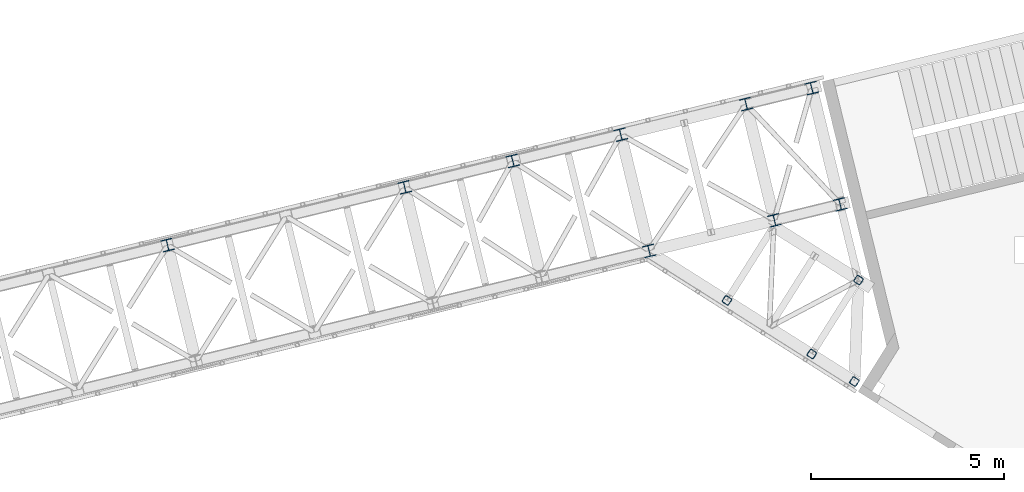
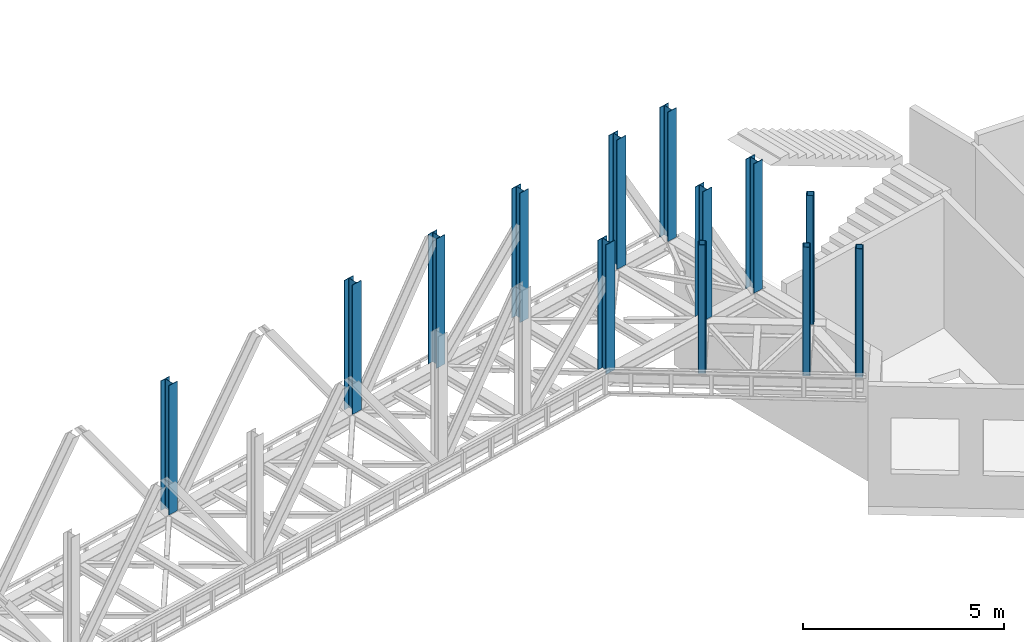
# One storey, part 3 of 93: 13 columns.
"""IFC4 building model written with IfcOpenShell, lengths in millimetres."""

from ifc_helpers import new_model, entity, si_unit, converted_unit, derived_unit, direction, frame, origin, place, context, subcontext, project, spatial, indexed_curve, outline, extrude, type_object, element, save


model = new_model("IFC4")

# Units and contexts
model_context = context("Model", 3, precision=0.01, world=origin(), true_north=direction((6.12303176911189e-17, 1.0)))
plan_context = context("Plan", 3, precision=0.01, world=origin(), true_north=direction((6.12303176911189e-17, 1.0)))
body_context = subcontext(model_context, "Body", "Model", "MODEL_VIEW")
ifc_project = project(units=[si_unit("LENGTHUNIT", "METRE", prefix="MILLI"), si_unit("AREAUNIT", "SQUARE_METRE"), si_unit("VOLUMEUNIT", "CUBIC_METRE"), converted_unit("PLANEANGLEUNIT", "DEGREE", entity("IfcRatioMeasure", 0.0174532925199433), si_unit("PLANEANGLEUNIT", "RADIAN"), dimensions=[0, 0, 0, 0, 0, 0, 0]), si_unit("MASSUNIT", "GRAM", prefix="KILO"), derived_unit("MASSDENSITYUNIT", [(si_unit("MASSUNIT", "GRAM", prefix="KILO"), 1), (si_unit("LENGTHUNIT", "METRE"), -3)]), derived_unit("MOMENTOFINERTIAUNIT", [(si_unit("LENGTHUNIT", "METRE"), 4)]), si_unit("TIMEUNIT", "SECOND"), si_unit("FREQUENCYUNIT", "HERTZ"), si_unit("THERMODYNAMICTEMPERATUREUNIT", "DEGREE_CELSIUS"), derived_unit("THERMALTRANSMITTANCEUNIT", [(si_unit("MASSUNIT", "GRAM", prefix="KILO"), 1), (si_unit("THERMODYNAMICTEMPERATUREUNIT", "KELVIN"), -1), (si_unit("TIMEUNIT", "SECOND"), -3)]), derived_unit("VOLUMETRICFLOWRATEUNIT", [(si_unit("LENGTHUNIT", "METRE"), 3), (si_unit("TIMEUNIT", "SECOND"), -1)]), derived_unit("MASSFLOWRATEUNIT", [(si_unit("MASSUNIT", "GRAM", prefix="KILO"), 1), (si_unit("TIMEUNIT", "SECOND"), -1)]), derived_unit("ROTATIONALFREQUENCYUNIT", [(si_unit("TIMEUNIT", "SECOND"), -1)]), si_unit("ELECTRICCURRENTUNIT", "AMPERE"), si_unit("ELECTRICVOLTAGEUNIT", "VOLT"), si_unit("POWERUNIT", "WATT"), si_unit("FORCEUNIT", "NEWTON", prefix="KILO"), si_unit("ILLUMINANCEUNIT", "LUX"), si_unit("LUMINOUSFLUXUNIT", "LUMEN"), si_unit("LUMINOUSINTENSITYUNIT", "CANDELA"), derived_unit("USERDEFINED", [(si_unit("MASSUNIT", "GRAM", prefix="KILO"), -1), (si_unit("LENGTHUNIT", "METRE"), -2), (si_unit("TIMEUNIT", "SECOND"), 3), (si_unit("LUMINOUSFLUXUNIT", "LUMEN"), 1)]), derived_unit("LINEARVELOCITYUNIT", [(si_unit("LENGTHUNIT", "METRE"), 1), (si_unit("TIMEUNIT", "SECOND"), -1)]), si_unit("PRESSUREUNIT", "PASCAL"), derived_unit("USERDEFINED", [(si_unit("LENGTHUNIT", "METRE"), -2), (si_unit("MASSUNIT", "GRAM", prefix="KILO"), 1), (si_unit("TIMEUNIT", "SECOND"), -2)]), derived_unit("LINEARFORCEUNIT", [(si_unit("MASSUNIT", "GRAM", prefix="KILO"), 1), (si_unit("LENGTHUNIT", "METRE"), 1), (si_unit("TIMEUNIT", "SECOND"), -2), (si_unit("LENGTHUNIT", "METRE"), -1)]), derived_unit("PLANARFORCEUNIT", [(si_unit("MASSUNIT", "GRAM", prefix="KILO"), 1), (si_unit("LENGTHUNIT", "METRE"), 1), (si_unit("TIMEUNIT", "SECOND"), -2), (si_unit("LENGTHUNIT", "METRE"), -2)])], contexts=[model_context, plan_context])

# Site, building, storey
site_placement = place(None, origin())
site = spatial("IfcSite", under=ifc_project, at=site_placement, CompositionType="ELEMENT")
building_placement = place(site_placement, origin())
building = spatial("IfcBuilding", under=site, at=building_placement, CompositionType="ELEMENT")
storey_placement = place(building_placement, frame((0.0, 0.0, 15900.0)))
storey = spatial("IfcBuildingStorey", under=building, at=storey_placement, CompositionType="ELEMENT", Elevation=15900.0)

# Columns
column_type_1 = type_object("IfcColumnType", PredefinedType="COLUMN")
column_1_placement = place(storey_placement, origin())
element("IfcColumn", 1, at=column_1_placement, inside=storey, type_object=column_type_1, ObjectType="Steel Column", PredefinedType="COLUMN", context=body_context, shape_type="SweptSolid", body=[
    extrude(outline(indexed_curve([(-149.999999999996, -149.999999999997), (-134.499999999996, -149.999999999997), (-134.499999999997, -22.9999999999994), (-133.1298315852, -16.1116982174372), (-129.227922061356, -10.2720779386417), (-123.388301782569, -6.37016841480137), (-116.499999999997, -5.0000000000034), (116.500000000004, -5.00000000000357), (123.388301782575, -6.37016841480053), (129.22792206136, -10.272077938641), (133.129831585207, -16.1116982174367), (134.500000000004, -22.9999999999993), (134.500000000004, -149.999999999996), (150.000000000004, -149.999999999997), (150.000000000002, 150.000000000005), (134.500000000004, 150.000000000004), (134.500000000003, 22.9999999999989), (133.129831585206, 16.1116982174278), (129.22792206136, 10.2720779386507), (123.388301782574, 6.37016841479246), (116.500000000003, 4.99999999999504), (-116.499999999999, 4.99999999999782), (-123.388301782571, 6.37016841478953), (-129.22792206136, 10.2720779386521), (-133.129831585201, 16.1116982174273), (-134.500000000001, 22.9999999999972), (-134.5, 149.999999999992), (-149.999999999998, 150.000000000004), (-149.999999999996, -149.999999999997)], self_intersect=False)), frame((-5412.09908652914, 16282.3206023644, 3685.0), z_axis=(0.0, 0.0, 1.0), x_axis=(-0.236826092990335, 0.971552058141474, 0.0)), (0.0, 0.0, 1.0), 3931.00000000001),
])
column_type_2 = type_object("IfcColumnType", PredefinedType="COLUMN")
column_2_placement = place(storey_placement, origin())
element("IfcColumn", 2, at=column_2_placement, inside=storey, type_object=column_type_2, ObjectType="Steel Column", PredefinedType="COLUMN", context=body_context, shape_type="SweptSolid", body=[
    extrude(outline(indexed_curve([(-149.999999999992, -150.000000000004), (-134.499999999992, -150.000000000004), (-134.499999999995, -23.0000000000064), (-133.129831585198, -16.1116982174347), (-129.227922061354, -10.2720779386484), (-123.388301782568, -6.37016841479899), (-116.499999999995, -5.00000000000143), (116.500000000005, -4.99999999999686), (123.388301782576, -6.3701684147945), (129.227922061362, -10.2720779386436), (133.129831585209, -16.1116982174297), (134.500000000006, -23.0000000000012), (134.500000000007, -149.999999999998), (150.000000000008, -149.999999999998), (150.000000000001, 150.000000000004), (134.500000000003, 150.000000000003), (134.500000000004, 23.0000000000146), (133.129831585207, 16.1116982174256), (129.227922061361, 10.2720779386482), (123.388301782575, 6.37016841479877), (116.500000000004, 5.00000000000095), (-116.499999999998, 5.00000000000006), (-123.388301782567, 6.37016841479402), (-129.227922061359, 10.2720779386449), (-133.129831585202, 16.1116982174205), (-134.5, 23.0000000000078), (-134.500000000001, 149.999999999996), (-149.999999999999, 149.999999999998), (-149.999999999992, -150.000000000004)], self_intersect=False)), frame((-2167.11521233662, 17073.3197529521, 3685.0), z_axis=(0.0, 0.0, 1.0), x_axis=(-0.236826092990319, 0.971552058141478, 0.0)), (0.0, 0.0, 1.0), 3931.00000000001),
])
column_type_3 = type_object("IfcColumnType", PredefinedType="COLUMN")
column_3_placement = place(storey_placement, origin())
element("IfcColumn", 3, at=column_3_placement, inside=storey, type_object=column_type_3, ObjectType="Steel Column", PredefinedType="COLUMN", context=body_context, shape_type="SweptSolid", body=[
    extrude(outline(indexed_curve([(-150.000000000001, -150.000000000001), (-134.5, -150.000000000001), (-134.500000000002, -22.9999999999947), (-133.129831585205, -16.1116982174319), (-129.227922061361, -10.2720779386456), (-123.388301782575, -6.37016841479614), (-116.500000000002, -4.9999999999988), (116.499999999999, -4.99999999999733), (123.38830178257, -6.37016841479492), (129.227922061355, -10.272077938644), (133.129831585202, -16.1116982174302), (134.499999999999, -22.9999999999931), (134.499999999999, -149.999999999999), (149.999999999999, -149.999999999999), (149.999999999997, 150.000000000003), (134.499999999998, 150.000000000002), (134.499999999998, 23.0000000000053), (133.129831585201, 16.1116982174337), (129.227922061355, 10.272077938639), (123.388301782568, 6.37016841480707), (116.499999999998, 5.00000000000929), (-116.500000000006, 4.99999999999419), (-123.388301782583, 6.37016841479406), (-129.227922061363, 10.2720779386316), (-133.129831585209, 16.1116982174316), (-134.500000000006, 23.0000000000023), (-134.500000000006, 149.999999999999), (-150.000000000003, 150.0), (-150.000000000001, -150.000000000001)], self_intersect=False)), frame((-466.899110589044, 17487.7654156852, 3685.0), z_axis=(0.0, 0.0, 1.0), x_axis=(-0.236826092990331, 0.971552058141475, 0.0)), (0.0, 0.0, 1.0), 3931.00000000001),
])
column_type_4 = type_object("IfcColumnType", PredefinedType="COLUMN")
column_4_placement = place(storey_placement, origin())
element("IfcColumn", 4, at=column_4_placement, inside=storey, type_object=column_type_4, ObjectType="Steel Column", PredefinedType="COLUMN", context=body_context, shape_type="SweptSolid", body=[
    extrude(outline(indexed_curve([(-150.000000000009, -149.999999999989), (-134.500000000008, -149.999999999989), (-134.499999999999, -22.9999999999834), (-133.129831585204, -16.1116982174208), (-129.227922061357, -10.2720779386351), (-123.38830178257, -6.37016841478617), (-116.499999999998, -4.99999999998972), (116.500000000001, -5.00000000000413), (123.388301782572, -6.37016841480157), (129.227922061359, -10.272077938653), (133.129831585204, -16.1116982174384), (134.5, -23.0000000000022), (134.499999999993, -150.000000000008), (149.999999999993, -150.000000000008), (150.000000000012, 149.999999999992), (134.500000000012, 149.999999999994), (134.500000000005, 22.9999999999887), (133.129831585207, 16.1116982174245), (129.22792206136, 10.2720779386298), (123.388301782574, 6.37016841478987), (116.500000000003, 4.9999999999929), (-116.499999999999, 5.00000000001255), (-123.388301782573, 6.3701684148084), (-129.227922061357, 10.2720779386504), (-133.129831585205, 16.111698217441), (-134.499999999997, 23.0000000000127), (-134.499999999989, 150.000000000016), (-149.999999999988, 150.000000000013), (-150.000000000009, -149.999999999989)], self_intersect=False)), frame((-17882.6088371482, 16433.2727792797, 3685.0), z_axis=(0.0, 0.0, 1.0), x_axis=(-0.236826092990401, 0.971552058141458, 0.0)), (0.0, 0.0, 1.0), 3931.00000000001),
])
column_type_5 = type_object("IfcColumnType", PredefinedType="COLUMN")
column_5_placement = place(storey_placement, origin())
element("IfcColumn", 5, at=column_5_placement, inside=storey, type_object=column_type_5, ObjectType="Steel Column", PredefinedType="COLUMN", context=body_context, shape_type="SweptSolid", body=[
    extrude(outline(indexed_curve([(-149.999999999988, -150.000000000005), (-134.499999999987, -150.000000000005), (-134.499999999997, -23.0000000000148), (-133.1298315852, -16.1116982174436), (-129.227922061354, -10.2720779386484), (-123.388301782568, -6.37016841480764), (-116.499999999998, -5.00000000000974), (116.500000000003, -4.99999999999305), (123.388301782574, -6.37016841479165), (129.227922061361, -10.2720779386312), (133.129831585207, -16.111698217425), (134.500000000004, -22.9999999999976), (134.500000000012, -149.999999999985), (150.000000000012, -149.999999999985), (149.999999999993, 150.000000000017), (134.499999999992, 150.000000000015), (134.5, 23.0000000000096), (133.129831585203, 16.1116982174295), (129.22792206136, 10.2720779386426), (123.388301782574, 6.37016841480189), (116.500000000001, 5.0000000000045), (-116.500000000001, 4.9999999999815), (-123.388301782567, 6.37016841478329), (-129.227922061358, 10.2720779386192), (-133.129831585202, 16.1116982174104), (-134.5, 22.9999999999876), (-134.50000000001, 149.999999999984), (-150.00000000001, 149.999999999995), (-149.999999999988, -150.000000000005)], self_intersect=False)), frame((-11742.3998296941, 17930.0136869786, 3685.0), z_axis=(0.0, 0.0, 1.0), x_axis=(-0.236826092990269, 0.97155205814149, 0.0)), (0.0, 0.0, 1.0), 3931.00000000001),
])
column_type_6 = type_object("IfcColumnType", PredefinedType="COLUMN")
column_6_placement = place(storey_placement, origin())
element("IfcColumn", 6, at=column_6_placement, inside=storey, type_object=column_type_6, ObjectType="Steel Column", PredefinedType="COLUMN", context=body_context, shape_type="SweptSolid", body=[
    extrude(outline(indexed_curve([(-149.999999999995, -150.000000000002), (-134.499999999995, -150.000000000002), (-134.499999999996, -22.9999999999962), (-133.129831585199, -16.111698217433), (-129.227922061352, -10.272077938647), (-123.388301782566, -6.37016841479767), (-116.499999999996, -5.00000000000024), (116.500000000005, -4.99999999999936), (123.388301782576, -6.37016841479738), (129.227922061364, -10.2720779386463), (133.129831585208, -16.1116982174325), (134.500000000006, -22.9999999999951), (134.500000000004, -150.000000000001), (150.000000000005, -150.0), (150.000000000006, 150.0), (134.500000000003, 150.0), (134.500000000004, 22.9999999999942), (133.129831585207, 16.111698217432), (129.227922061363, 10.2720779386365), (123.388301782577, 6.37016841480404), (116.500000000004, 5.00000000000712), (-116.499999999998, 4.9999999999931), (-123.388301782573, 6.37016841479215), (-129.227922061356, 10.2720779386311), (-133.129831585202, 16.1116982174309), (-134.499999999995, 22.9999999999915), (-134.499999999997, 149.999999999996), (-149.999999999996, 149.999999999999), (-149.999999999995, -150.000000000002)], self_intersect=False)), frame((-8944.32990224665, 18612.0728347908, 3685.0), z_axis=(0.0, 0.0, 1.0), x_axis=(-0.236826092990335, 0.971552058141474, 0.0)), (0.0, 0.0, 1.0), 3931.00000000001),
])
column_type_7 = type_object("IfcColumnType", PredefinedType="COLUMN")
column_7_placement = place(storey_placement, origin())
element("IfcColumn", 7, at=column_7_placement, inside=storey, type_object=column_type_7, ObjectType="Steel Column", PredefinedType="COLUMN", context=body_context, shape_type="SweptSolid", body=[
    extrude(outline(indexed_curve([(-149.999999999997, -150.000000000001), (-134.499999999997, -150.000000000001), (-134.499999999998, -23.0000000000036), (-133.129831585201, -16.1116982174325), (-129.227922061355, -10.2720779386464), (-123.388301782568, -6.37016841479716), (-116.499999999998, -4.99999999999867), (116.500000000003, -4.99999999999885), (123.388301782574, -6.37016841479581), (129.227922061361, -10.2720779386458), (133.129831585206, -16.111698217432), (134.500000000003, -23.0000000000035), (134.500000000003, -150.0), (150.000000000003, -150.0), (150.000000000004, 150.000000000001), (134.500000000003, 150.000000000001), (134.500000000002, 23.0000000000125), (133.129831585205, 16.1116982174236), (129.227922061361, 10.272077938646), (123.388301782575, 6.37016841479667), (116.500000000002, 4.9999999999987), (-116.499999999995, 5.00000000000257), (-123.388301782567, 6.37016841479638), (-129.227922061361, 10.2720779386489), (-133.129831585202, 16.1116982174241), (-134.5, 23.0000000000104), (-134.499999999999, 149.999999999998), (-149.999999999999, 150.0), (-149.999999999997, -150.000000000001)], self_intersect=False)), frame((-6146.25997479919, 19294.1319826029, 3685.0), z_axis=(0.0, 0.0, 1.0), x_axis=(-0.236826092990335, 0.971552058141474, 0.0)), (0.0, 0.0, 1.0), 3931.00000000001),
])
column_type_8 = type_object("IfcColumnType", PredefinedType="COLUMN")
column_8_placement = place(storey_placement, origin())
element("IfcColumn", 8, at=column_8_placement, inside=storey, type_object=column_type_8, ObjectType="Steel Column", PredefinedType="COLUMN", context=body_context, shape_type="SweptSolid", body=[
    extrude(outline(indexed_curve([(-150.000000000002, -150.000000000001), (-134.500000000001, -150.000000000001), (-134.500000000002, -23.0000000000041), (-133.129831585203, -16.1116982174241), (-129.227922061361, -10.272077938646), (-123.388301782573, -6.37016841478825), (-116.500000000002, -4.99999999999082), (116.499999999998, -4.99999999999048), (123.388301782569, -6.37016841478797), (129.227922061355, -10.2720779386453), (133.129831585202, -16.1116982174231), (134.499999999997, -23.000000000003), (134.499999999998, -150.0), (149.999999999998, -150.0), (149.999999999997, 150.000000000001), (134.499999999997, 150.000000000001), (134.499999999998, 23.0000000000036), (133.129831585203, 16.111698217423), (129.227922061355, 10.2720779386375), (123.388301782568, 6.37016841480555), (116.499999999998, 5.0000000000076), (-116.500000000004, 5.00000000000199), (-123.388301782586, 6.37016841479418), (-129.227922061352, 10.27207793864), (-133.129831585206, 16.1116982174225), (-134.500000000006, 23.0000000000014), (-134.500000000007, 149.999999999999), (-150.000000000003, 150.0), (-150.000000000002, -150.000000000001)], self_intersect=False)), frame((-2901.27610060667, 20085.1311331907, 3685.0), z_axis=(0.0, 0.0, 1.0), x_axis=(-0.236826092990335, 0.971552058141474, 0.0)), (0.0, 0.0, 1.0), 3931.00000000001),
])
column_type_9 = type_object("IfcColumnType", PredefinedType="COLUMN")
column_9_placement = place(storey_placement, origin())
element("IfcColumn", 9, at=column_9_placement, inside=storey, type_object=column_type_9, ObjectType="Steel Column", PredefinedType="COLUMN", context=body_context, shape_type="SweptSolid", body=[
    extrude(outline(indexed_curve([(-150.000000000001, -149.999999999998), (-134.500000000001, -149.999999999998), (-134.499999999997, -23.0000000000021), (-133.1298315852, -16.1116982174305), (-129.227922061356, -10.2720779386442), (-123.38830178257, -6.37016841479494), (-116.499999999997, -5.00000000000616), (116.499999999999, -5.00000000000491), (123.388301782572, -6.37016841479425), (129.22792206136, -10.2720779386437), (133.129831585205, -16.1116982174296), (134.500000000002, -23.0000000000013), (134.500000000003, -149.999999999999), (150.000000000003, -149.999999999998), (150.000000000002, 150.000000000003), (134.500000000002, 150.000000000003), (134.500000000001, 22.999999999997), (133.129831585204, 16.1116982174257), (129.227922061361, 10.2720779386475), (123.388301782571, 6.37016841479901), (116.5, 5.00000000000105), (-116.500000000002, 4.99999999999571), (-123.388301782567, 6.37016841479756), (-129.227922061365, 10.2720779386414), (-133.129831585201, 16.1116982174245), (-134.499999999999, 22.9999999999942), (-134.500000000002, 150.000000000001), (-149.999999999998, 150.000000000002), (-150.000000000001, -149.999999999998)], self_intersect=False)), frame((-1201.0599988591, 20499.5767959238, 3685.0), z_axis=(0.0, 0.0, 1.0), x_axis=(-0.236826092990335, 0.971552058141474, 0.0)), (0.0, 0.0, 1.0), 3931.00000000001),
])
column_type_10 = type_object("IfcColumnType", PredefinedType="COLUMN")
column_10_placement = place(storey_placement, origin())
element("IfcColumn", 10, at=column_10_placement, inside=storey, type_object=column_type_10, ObjectType="Steel Column", PredefinedType="COLUMN", context=body_context, shape_type="SweptSolid", body=[
    extrude(outline(indexed_curve([(49.1459374271497, -111.734850581474), (60.8513567481022, -111.734850581474), (71.6657540781827, -107.255380538444), (79.9427354566247, -98.9783991599474), (84.4222054995761, -88.164001829847), (111.73485058112, 49.1459374266677), (111.734850581068, 60.8513567476448), (107.255380537993, 71.6657540777505), (98.9783991594631, 79.9427354562349), (88.164001829344, 84.422205499254), (-49.1459374271436, 111.734850581483), (-60.8513567481105, 111.734850581473), (-71.6657540781771, 107.255380538453), (-79.9427354566186, 98.9783991599569), (-84.4222054995844, 88.164001829846), (-111.734850581129, -49.1459374266687), (-111.734850581063, -60.8513567476355), (-107.255380537988, -71.6657540777412), (-98.9783991594714, -79.9427354562359), (-88.1640018293524, -84.422205499255), (49.1459374271497, -111.734850581474)], self_intersect=False), holes=[indexed_curve([(-76.4052458051974, -76.5652559153672), (-87.2196431353149, -72.0857858723521), (-95.4966245138426, -63.8088044938667), (-99.9760945569088, -52.9944071637622), (-99.9760945569793, -41.2889878427855), (-76.5652559156544, 76.4052458056415), (-72.0857858726852, 87.2196431357655), (-63.8088044942536, 95.4966245142528), (-52.9944071641797, 99.9760945572851), (-41.2889878432147, 99.9760945572831), (76.4052458052092, 76.5652559153813), (87.2196431353298, 72.0857858723628), (95.4966245138503, 63.8088044938722), (99.9760945569322, 52.9944071637623), (99.9760945569808, 41.2889878427978), (76.565255915663, -76.4052458056497), (72.0857858727068, -87.2196431357497), (63.8088044942605, -95.4966245142454), (52.9944071641819, -99.9760945572702), (41.2889878432301, -99.9760945572722), (-76.4052458051974, -76.5652559153672)], self_intersect=False)]), frame((-3398.01777842913, 15001.7173673892, 3704.04999999999), z_axis=(0.0, 0.0, 1.0), x_axis=(0.927336857834339, -0.374227674152961, 0.0)), (0.0, 0.0, 1.0), 3911.94999999865),
])
column_type_11 = type_object("IfcColumnType", PredefinedType="COLUMN")
column_11_placement = place(storey_placement, origin())
element("IfcColumn", 11, at=column_11_placement, inside=storey, type_object=column_type_11, ObjectType="Steel Column", PredefinedType="COLUMN", context=body_context, shape_type="SweptSolid", body=[
    extrude(outline(indexed_curve([(49.1459374271164, -111.734850581488), (60.8513567480769, -111.734850581488), (71.6657540781519, -107.255380538466), (79.9427354565958, -98.9783991599725), (84.4222054995496, -88.1640018298711), (111.734850581139, 49.1459374266412), (111.734850581084, 60.8513567476111), (107.255380538012, 71.6657540777182), (98.978399159483, 79.9427354562066), (88.1640018293653, 84.4222054992288), (-49.145937427114, 111.734850581494), (-60.8513567480805, 111.734850581487), (-71.6657540781486, 107.25538053847), (-79.9427354565935, 98.9783991599781), (-84.422205499554, 88.1640018298717), (-111.734850581143, -49.1459374266407), (-111.734850581081, -60.8513567476055), (-107.255380538016, -71.6657540777197), (-98.9783991594876, -79.9427354562061), (-88.1640018293708, -84.4222054992264), (49.1459374271164, -111.734850581488)], self_intersect=False), holes=[indexed_curve([(-76.4052458052286, -76.5652559153525), (-87.2196431353317, -72.0857858723221), (-95.4966245138585, -63.8088044938397), (-99.9760945569253, -52.994407163726), (-99.9760945569795, -41.2889878427604), (-76.565255915633, 76.4052458056721), (-72.0857858726692, 87.2196431357797), (-63.8088044942326, 95.4966245142753), (-52.9944071641458, 99.9760945572999), (-41.2889878431907, 99.9760945573), (76.4052458052273, 76.5652559153613), (87.2196431353477, 72.0857858723379), (95.4966245138657, 63.8088044938449), (99.9760945569434, 52.9944071637356), (99.9760945569909, 41.2889878427674), (76.5652559156335, -76.4052458056765), (72.08578587268, -87.2196431357707), (63.8088044942338, -95.4966245142678), (52.9944071641561, -99.9760945572911), (41.2889878432009, -99.9760945572913), (-76.4052458052286, -76.5652559153525)], self_intersect=False)]), frame((-1200.35424810374, 13612.3739946127, 3704.04999999999), z_axis=(0.0, 0.0, 1.0), x_axis=(0.927336857834443, -0.374227674152704, 0.0)), (0.0, 0.0, 1.0), 3911.94999999865),
])
column_type_12 = type_object("IfcColumnType", PredefinedType="COLUMN")
column_12_placement = place(storey_placement, origin())
element("IfcColumn", 12, at=column_12_placement, inside=storey, type_object=column_type_12, ObjectType="Steel Column", PredefinedType="COLUMN", context=body_context, shape_type="SweptSolid", body=[
    extrude(outline(indexed_curve([(49.1459374271479, -111.734850581477), (60.8513567481005, -111.734850581477), (71.6657540781822, -107.255380538449), (79.942735456624, -98.9783991599525), (84.4222054995816, -88.1640018298449), (111.73485058112, 49.1459374266626), (111.734850581068, 60.8513567476397), (107.255380537992, 71.6657540777475), (98.9783991594696, 79.9427354562349), (88.1640018293507, 84.4222054992541), (-49.1459374271442, 111.734850581479), (-60.8513567481046, 111.734850581475), (-71.6657540781775, 107.255380538448), (-79.9427354566199, 98.9783991599542), (-84.4222054995847, 88.1640018298413), (-111.734850581122, -49.1459374266682), (-111.734850581063, -60.8513567476401), (-107.255380537988, -71.6657540777459), (-98.9783991594718, -79.9427354562404), (-88.1640018293538, -84.4222054992577), (49.1459374271479, -111.734850581477)], self_intersect=False), holes=[indexed_curve([(-76.405245805199, -76.5652559153723), (-87.2196431353247, -72.0857858723581), (-95.4966245138401, -63.8088044938678), (-99.9760945569111, -52.9944071637605), (-99.9760945569715, -41.2889878427845), (-76.5652559156569, 76.4052458056406), (-72.0857858727002, 87.2196431357549), (-63.8088044942489, 95.4966245142572), (-52.9944071641895, 99.9760945572789), (-41.288987843225, 99.976094557279), (76.405245805199, 76.5652559153769), (87.2196431353195, 72.0857858723584), (95.4966245138483, 63.8088044938711), (99.9760945569213, 52.9944071637623), (99.9760945569802, 41.2889878427926), (76.5652559156549, -76.4052458056438), (72.0857858726969, -87.2196431357562), (63.8088044942512, -95.4966245142516), (52.9944071641729, -99.9760945572739), (41.2889878432206, -99.9760945572808), (-76.405245805199, -76.5652559153723)], self_intersect=False)]), frame((-97.5109550487842, 12899.1947482045, 3704.05000000002), z_axis=(0.0, 0.0, 1.0), x_axis=(0.92733685783434, -0.37422767415296, 0.0)), (0.0, 0.0, 1.0), 3911.94999999863),
])
column_type_13 = type_object("IfcColumnType", PredefinedType="COLUMN")
column_13_placement = place(storey_placement, origin())
element("IfcColumn", 13, at=column_13_placement, inside=storey, type_object=column_type_13, ObjectType="Steel Column", PredefinedType="COLUMN", context=body_context, shape_type="SweptSolid", body=[
    extrude(outline(indexed_curve([(49.1459374271653, -111.734850581469), (60.8513567481188, -111.734850581469), (71.6657540781987, -107.255380538437), (79.9427354566391, -98.9783991599396), (84.4222054995957, -88.1640018298332), (111.73485058111, 49.145937426681), (111.734850581056, 60.851356747658), (107.255380537979, 71.6657540777631), (98.9783991594545, 79.9427354562511), (88.164001829335, 84.4222054992685), (-49.1459374271645, 111.73485058147), (-60.8513567481242, 111.734850581462), (-71.6657540781971, 107.255380538435), (-79.9427354566384, 98.9783991599399), (-84.422205499601, 88.1640018298264), (-111.734850581115, -49.1459374266878), (-111.734850581054, -60.8513567476597), (-107.255380537978, -71.6657540777648), (-98.9783991594459, -79.9427354562476), (-88.1640018293263, -84.422205499265), (49.1459374271653, -111.734850581469)], self_intersect=False), holes=[indexed_curve([(-76.4052458051801, -76.5652559153829), (-87.2196431353051, -72.0857858723723), (-95.4966245138212, -63.8088044938761), (-99.9760945568963, -52.9944071637752), (-99.9760945569587, -41.2889878427991), (-76.5652559156719, 76.4052458056267), (-72.0857858727091, 87.219643135745), (-63.8088044942591, 95.4966245142487), (-52.9944071641943, 99.9760945572747), (-41.2889878432332, 99.9760945572872), (76.4052458051925, 76.5652559153902), (87.2196431353133, 72.0857858723756), (95.4966245138369, 63.8088044938824), (99.9760945569188, 52.9944071637795), (99.9760945569709, 41.2889878428087), (76.5652559156743, -76.4052458056305), (72.0857858727174, -87.2196431357416), (63.808804494274, -95.4966245142404), (52.9944071642026, -99.9760945572621), (41.2889878432433, -99.9760945572714), (-76.4052458051801, -76.5652559153829)], self_intersect=False)]), frame((10.7791189717591, 15528.1449144152, 3685.0), z_axis=(0.0, 0.0, 1.0), x_axis=(0.927336857834276, -0.374227674153116, 0.0)), (0.0, 0.0, 1.0), 3911.94999999863),
])

save(model, "model.ifc")
